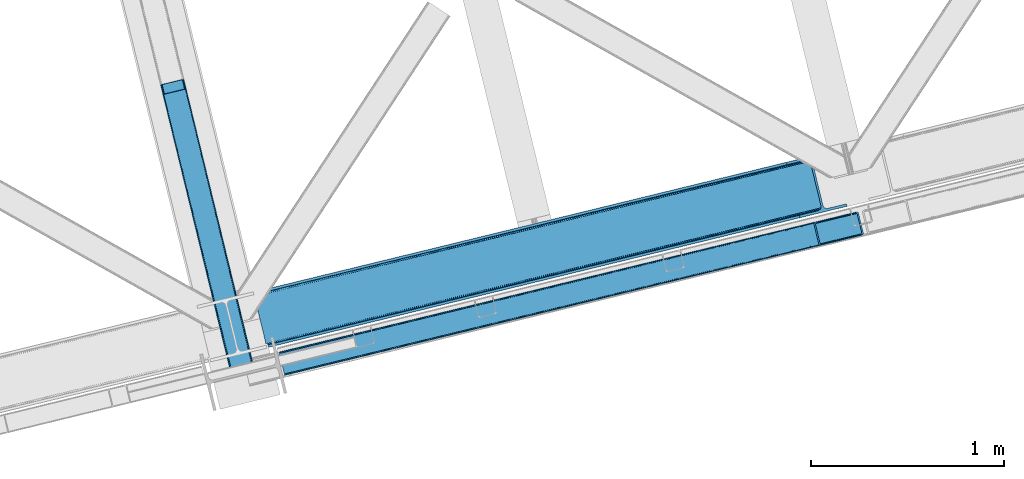
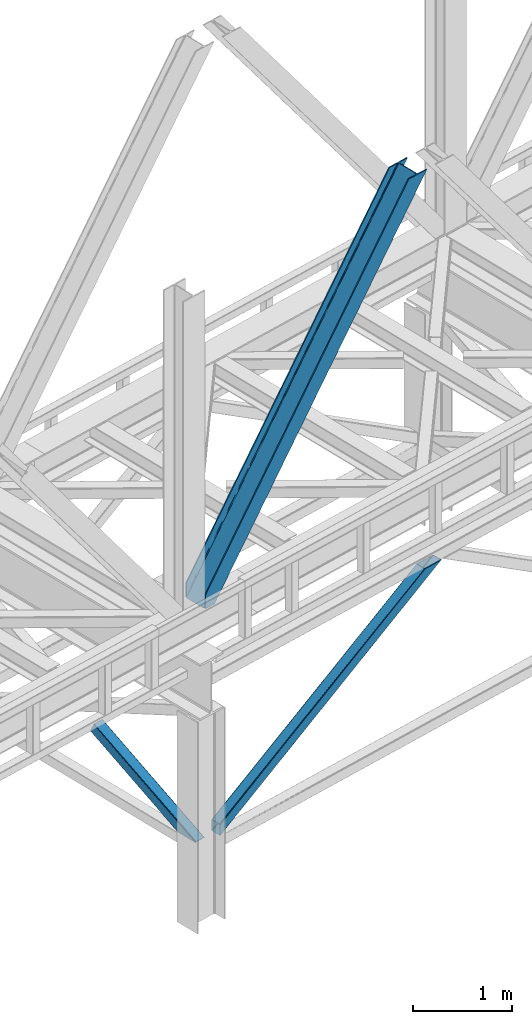
# One storey, part 42 of 93: 3 members.
"""IFC4 building model written with IfcOpenShell, lengths in millimetres."""

from ifc_helpers import new_model, entity, si_unit, converted_unit, derived_unit, direction, frame, origin, place, context, subcontext, project, spatial, triangles, polygons, type_object, element, save


model = new_model("IFC4")

# Units and contexts
model_context = context("Model", 3, precision=0.01, world=origin(), true_north=direction((6.12303176911189e-17, 1.0)))
plan_context = context("Plan", 3, precision=0.01, world=origin(), true_north=direction((6.12303176911189e-17, 1.0)))
body_context = subcontext(model_context, "Body", "Model", "MODEL_VIEW")
ifc_project = project(units=[si_unit("LENGTHUNIT", "METRE", prefix="MILLI"), si_unit("AREAUNIT", "SQUARE_METRE"), si_unit("VOLUMEUNIT", "CUBIC_METRE"), converted_unit("PLANEANGLEUNIT", "DEGREE", entity("IfcRatioMeasure", 0.0174532925199433), si_unit("PLANEANGLEUNIT", "RADIAN"), dimensions=[0, 0, 0, 0, 0, 0, 0]), si_unit("MASSUNIT", "GRAM", prefix="KILO"), derived_unit("MASSDENSITYUNIT", [(si_unit("MASSUNIT", "GRAM", prefix="KILO"), 1), (si_unit("LENGTHUNIT", "METRE"), -3)]), derived_unit("MOMENTOFINERTIAUNIT", [(si_unit("LENGTHUNIT", "METRE"), 4)]), si_unit("TIMEUNIT", "SECOND"), si_unit("FREQUENCYUNIT", "HERTZ"), si_unit("THERMODYNAMICTEMPERATUREUNIT", "DEGREE_CELSIUS"), derived_unit("THERMALTRANSMITTANCEUNIT", [(si_unit("MASSUNIT", "GRAM", prefix="KILO"), 1), (si_unit("THERMODYNAMICTEMPERATUREUNIT", "KELVIN"), -1), (si_unit("TIMEUNIT", "SECOND"), -3)]), derived_unit("VOLUMETRICFLOWRATEUNIT", [(si_unit("LENGTHUNIT", "METRE"), 3), (si_unit("TIMEUNIT", "SECOND"), -1)]), derived_unit("MASSFLOWRATEUNIT", [(si_unit("MASSUNIT", "GRAM", prefix="KILO"), 1), (si_unit("TIMEUNIT", "SECOND"), -1)]), derived_unit("ROTATIONALFREQUENCYUNIT", [(si_unit("TIMEUNIT", "SECOND"), -1)]), si_unit("ELECTRICCURRENTUNIT", "AMPERE"), si_unit("ELECTRICVOLTAGEUNIT", "VOLT"), si_unit("POWERUNIT", "WATT"), si_unit("FORCEUNIT", "NEWTON", prefix="KILO"), si_unit("ILLUMINANCEUNIT", "LUX"), si_unit("LUMINOUSFLUXUNIT", "LUMEN"), si_unit("LUMINOUSINTENSITYUNIT", "CANDELA"), derived_unit("USERDEFINED", [(si_unit("MASSUNIT", "GRAM", prefix="KILO"), -1), (si_unit("LENGTHUNIT", "METRE"), -2), (si_unit("TIMEUNIT", "SECOND"), 3), (si_unit("LUMINOUSFLUXUNIT", "LUMEN"), 1)]), derived_unit("LINEARVELOCITYUNIT", [(si_unit("LENGTHUNIT", "METRE"), 1), (si_unit("TIMEUNIT", "SECOND"), -1)]), si_unit("PRESSUREUNIT", "PASCAL"), derived_unit("USERDEFINED", [(si_unit("LENGTHUNIT", "METRE"), -2), (si_unit("MASSUNIT", "GRAM", prefix="KILO"), 1), (si_unit("TIMEUNIT", "SECOND"), -2)]), derived_unit("LINEARFORCEUNIT", [(si_unit("MASSUNIT", "GRAM", prefix="KILO"), 1), (si_unit("LENGTHUNIT", "METRE"), 1), (si_unit("TIMEUNIT", "SECOND"), -2), (si_unit("LENGTHUNIT", "METRE"), -1)]), derived_unit("PLANARFORCEUNIT", [(si_unit("MASSUNIT", "GRAM", prefix="KILO"), 1), (si_unit("LENGTHUNIT", "METRE"), 1), (si_unit("TIMEUNIT", "SECOND"), -2), (si_unit("LENGTHUNIT", "METRE"), -2)])], contexts=[model_context, plan_context])

# Site, building, storey
site_placement = place(None, origin())
site = spatial("IfcSite", under=ifc_project, at=site_placement, CompositionType="ELEMENT")
building_placement = place(site_placement, origin())
building = spatial("IfcBuilding", under=site, at=building_placement, CompositionType="ELEMENT")
storey_placement = place(building_placement, frame((0.0, 0.0, 15900.0)))
storey = spatial("IfcBuildingStorey", under=building, at=storey_placement, CompositionType="ELEMENT", Elevation=15900.0)

# Members
member_type_1 = type_object("IfcMemberType", PredefinedType="BRACE")
member_1_placement = place(storey_placement, frame((-41961.0666503906, 7062.34799194336, 965.735650634766)))
element("IfcMember", 1, at=member_1_placement, inside=storey, type_object=member_type_1, ObjectType="Steel Vertical Brace", PredefinedType="BRACE", context=body_context, shape_type="Tessellation", body=[
    triangles([(2998.54487915039, 840.490557861329, 1902.27225952148), (3024.23633422852, 734.561558532715, 1902.27225952148), (42.5415893554673, 11.3696548461912, 4.45903015136719), (16.6222412109346, 117.244006347656, 4.31717834472511), (0.176733398438955, 120.724607849122, 0.782510375975107), (0.0, 121.44375, 4.34159545898365), (2981.88078002929, 844.680418395997, 1902.27225952148), (2987.68042602539, 845.46060333252, 1902.27225952148), (2992.88243408203, 844.93796081543, 1902.27225952148), (7.26932373047021, 120.796115112305, 1.96615905761428), (2996.69848022461, 843.192718505859, 1902.27225952148), (13.8131103515625, 119.713041687012, 3.70442504882521), (0.213940429683134, 120.566477966308, 0.0), (3016.85538940429, 725.165620422364, 1902.27225952148), (29.4307617187515, 0.712165832519531, 0.868551635740005), (35.8768798828096, 3.93231811523492, 2.12312622070021), (29.3935546875, 0.86041259765625, 0.127899169921875), (3011.34642333984, 723.202949523926, 1902.27225952148), (29.6028442382813, 0.0, 4.43112487792678), (3021.24349365234, 728.014283752442, 1902.27225952148), (3023.83403320312, 731.313500976563, 1902.27225952148), (41.1835327148438, 7.89079742431659, 3.85441589355469), (0.0, 121.44375, 132.509353637695), (2780.51400146484, 795.840376281739, 1902.27225952148), (0.27440185546584, 120.305447387695, 135.835894775388), (2775.00270996094, 793.876542663575, 1902.27225952148), (0.55345458984084, 119.167726135254, 139.162435913084), (2770.61693115234, 791.02846069336, 1902.27225952148), (1.22318115234521, 116.419638061524, 140.541421508788), (2768.02639160156, 787.729243469239, 1902.27225952148), (1.89290771484229, 113.671549987793, 141.921569824219), (2767.62176513672, 784.481185913086, 1902.27225952148), (2793.31322021484, 678.552767944337, 1902.27225952148), (27.709936523439, 7.77220001220758, 141.999472045896), (28.379663085936, 5.02411193847638, 140.622811889647), (2795.15961914062, 675.850025939942, 1902.27225952148), (29.0493896484331, 2.27660522460974, 139.247314453125), (2798.97333984375, 674.104783630371, 1902.27225952148), (29.3237915039063, 1.13830261230487, 135.92309875488), (2804.17767333984, 673.582722473145, 1902.27225952148), (29.6028442382813, 0.0, 132.597720336911), (2809.97731933594, 674.362326049805, 1902.27225952148), (3.90208740234084, 110.042120361329, 0.32207336425563), (27.914575195311, 11.9382247924805, 0.453460693359375), (27.3053100585894, 9.42209930419904, 0.118597412107192), (2.32078857421584, 111.926307678223, 0.00930175781104481), (3015.90428466797, 736.656198120118, 1902.27225952148), (2992.09876098633, 834.810671997071, 1902.27225952148), (1.62315673827834, 114.773808288574, 3.08236999511428), (2986.43864135742, 839.258656311035, 1902.27225952148), (2981.23430786133, 839.780717468262, 1902.27225952148), (2.17196044921729, 112.539060974122, 0.67088928222438), (2990.25236206054, 837.513414001465, 1902.27225952148), (1.09295654296875, 116.966116333008, 5.44850463866896), (2975.43466186523, 839.001113891602, 1902.27225952148), (0.94877929687209, 117.557940673828, 9.04828491210719), (28.379663085936, 5.02411193847638, 5.80429687499782), (28.6540649414019, 3.88580932617242, 9.13083801269386), (3003.01204833984, 725.297589111328, 1902.27225952148), (28.100610351561, 6.16241455078125, 2.47775573730178), (3008.5256652832, 727.261422729493, 1902.27225952148), (27.4680908203081, 8.76167449951208, 0.596475219725107), (3012.90911865234, 730.108923339844, 1902.27225952148), (3015.50198364258, 733.408721923828, 1902.27225952148), (0.94877929687209, 117.557940673828, 127.808477783201), (2788.84837646484, 793.745155334473, 1902.27225952148), (2.17196044921729, 112.533247375489, 135.841708374021), (2776.35611572266, 785.634603881836, 1902.27225952148), (2775.95148925781, 782.385964965821, 1902.27225952148), (1.50223388672021, 115.281335449219, 134.461560058593), (2778.95130615234, 788.933821105958, 1902.27225952148), (1.22318115234521, 116.419638061524, 131.135018920897), (2783.33708496093, 791.781903076172, 1902.27225952148), (2.84168701171438, 109.785159301758, 137.220693969724), (2805.42410888672, 679.784669494629, 1902.27225952148), (2801.60573730469, 681.529911804199, 1902.27225952148), (2816.4234375, 680.041630554199, 1902.27225952148), (2810.62844238281, 679.26202697754, 1902.27225952148), (2799.75933837891, 684.231491088867, 1902.27225952148), (28.379663085936, 5.02411193847638, 131.216409301756), (28.100610351561, 6.16241455078125, 134.541787719725), (27.430883789064, 8.91050262451154, 135.917285156247), (26.7611572265596, 11.6585906982427, 137.292782592773), (28.6540649414019, 3.88580932617242, 127.891030883788)], [[1, 2, 3], [3, 4, 1], [5, 6, 7], [8, 9, 10], [10, 5, 8], [11, 1, 4], [4, 12, 11], [9, 11, 12], [12, 10, 9], [10, 13, 5], [7, 8, 5], [14, 15, 16], [15, 17, 16], [15, 14, 18], [18, 19, 15], [16, 20, 14], [21, 20, 22], [16, 22, 20], [2, 21, 3], [22, 3, 21], [6, 23, 24], [24, 7, 6], [23, 25, 26], [25, 27, 28], [27, 29, 30], [29, 31, 32], [32, 30, 29], [30, 28, 27], [28, 26, 25], [26, 24, 23], [33, 32, 34], [31, 34, 32], [35, 36, 33], [37, 38, 36], [39, 40, 38], [41, 42, 40], [40, 39, 41], [38, 37, 39], [36, 35, 37], [33, 34, 35], [41, 19, 42], [18, 42, 19], [43, 10, 12], [44, 3, 22], [44, 22, 16], [3, 44, 4], [12, 4, 43], [43, 4, 44], [16, 45, 44], [16, 17, 45], [10, 46, 13], [46, 10, 43], [47, 48, 44], [43, 44, 48], [49, 50, 51], [52, 53, 50], [53, 46, 43], [53, 52, 46], [43, 48, 53], [50, 49, 52], [51, 54, 49], [51, 55, 54], [56, 54, 55], [57, 58, 59], [60, 57, 61], [62, 60, 63], [64, 47, 44], [44, 45, 64], [45, 62, 64], [63, 64, 62], [61, 63, 60], [59, 61, 57], [65, 56, 66], [55, 66, 56], [67, 68, 69], [70, 71, 68], [72, 73, 71], [65, 66, 73], [73, 72, 65], [71, 70, 72], [68, 67, 70], [69, 74, 67], [53, 9, 8], [48, 2, 1], [11, 53, 1], [53, 11, 9], [53, 48, 1], [50, 53, 8], [55, 7, 24], [7, 50, 8], [51, 7, 55], [51, 50, 7], [20, 64, 14], [47, 2, 48], [2, 64, 21], [64, 2, 47], [20, 21, 64], [18, 59, 42], [14, 64, 63], [63, 61, 18], [61, 59, 18], [18, 14, 63], [71, 26, 68], [24, 66, 55], [24, 73, 66], [71, 24, 26], [71, 73, 24], [69, 32, 33], [68, 26, 28], [30, 68, 28], [68, 30, 32], [69, 68, 32], [40, 75, 76], [42, 59, 77], [77, 78, 42], [78, 75, 42], [40, 42, 75], [38, 40, 76], [33, 79, 69], [76, 33, 36], [33, 76, 79], [36, 38, 76], [41, 39, 80], [81, 35, 82], [37, 81, 39], [81, 37, 35], [80, 39, 81], [83, 31, 74], [82, 35, 34], [34, 83, 82], [34, 31, 83], [80, 84, 41], [19, 60, 17], [19, 41, 84], [84, 58, 19], [19, 58, 57], [60, 19, 57], [60, 62, 17], [23, 65, 72], [70, 25, 72], [31, 29, 67], [31, 67, 74], [67, 29, 70], [25, 23, 72], [70, 29, 27], [70, 27, 25], [23, 56, 65], [49, 13, 46], [49, 54, 5], [5, 13, 49], [54, 56, 6], [23, 6, 56], [54, 6, 5], [69, 79, 83], [83, 74, 69], [84, 80, 78], [80, 81, 75], [81, 82, 76], [82, 83, 79], [79, 76, 82], [76, 75, 81], [75, 78, 80], [78, 77, 84], [58, 84, 77], [77, 59, 58]]),
])
member_type_2 = type_object("IfcMemberType", PredefinedType="BRACE")
member_2_placement = place(storey_placement, frame((-42089.4448608398, 7208.30478057861, 3694.99929199219)))
element("IfcMember", 2, at=member_2_placement, inside=storey, type_object=member_type_2, ObjectType="Steel Vertical Brace", PredefinedType="BRACE", context=body_context, shape_type="Tessellation", body=[
    triangles([(58.5266601562471, 27.8796936035151, 0.0), (60.4474731445298, 20.0011047363278, 0.0), (59.0940673828154, 20.928955078125, 0.827856445310317), (58.9684936523408, 19.7534454345705, 1.13248901367115), (72.2095458984404, 11.6585906982418, 0.0), (71.3956420898467, 13.9003143310547, 30.563250732419), (70.2236206054658, 15.4356857299799, 25.1542785644524), (72.2095458984404, 11.6585906982418, 171.175598144531), (71.9258422851563, 12.6195785522459, 42.2602111816377), (71.9258422851563, 12.6195785522459, 171.115136718749), (70.3910522460938, 15.5600967407227, 0.0), (68.8144042968779, 17.2873168945307, 18.6337463378877), (67.2145019531235, 18.4651519775389, 14.6921264648408), (63.168237304686, 19.929597473144, 7.29955444335792), (63.168237304686, 19.929597473144, 0.0), (67.2145019531235, 18.4651519775389, 0.0), (2821.27895507812, 682.803089904785, 3911.00081176758), (2916.00805664063, 705.89354095459, 3911.00081176758), (2933.63488769531, 721.627464294434, 3911.00081176758), (2930.26300048828, 714.795323181153, 3911.00081176758), (2933.67209472656, 728.727030944824, 3911.00081176758), (2924.07268066406, 709.270079040527, 3911.00081176758), (2824.35783691406, 670.173046875, 3911.00081176758), (75.0512329101548, 0.0, 171.175598144531), (75.0512329101548, 0.0, 0.0), (192.881249999999, 28.7220840454102, 0.0), (3068.02668457032, 729.569421386719, 3911.00081176758), (3064.94780273437, 742.199464416504, 3911.00081176758), (189.802368164063, 41.3521270751953, 0.0), (2970.22335205078, 719.109594726562, 3911.00081176758), (95.0779174804702, 18.2622573852541, 0.0), (2961.50295410156, 718.394522094726, 3911.00081176758), (86.3575195312515, 17.5477661132809, 0.0), (2953.46623535156, 720.451373291015, 3911.00081176758), (78.32080078125, 19.6040359497065, 0.0), (2947.32707519531, 724.966213989258, 3911.00081176758), (72.181640625, 24.118876647949, 0.0), (2944.02960205078, 731.251295471191, 3911.00081176758), (68.8841674804717, 30.403958129883, 0.0), (2888.84692382813, 957.622943115234, 3911.00081176758), (13.7014892578154, 256.775605773926, 0.0), (2888.88413085938, 964.722509765625, 3911.00081176758), (13.7386962890596, 263.875172424317, 0.0), (2892.25601806641, 971.554650878907, 3911.00081176758), (17.1105834960908, 270.707313537598, 0.0), (2898.44633789062, 977.079895019531, 3911.00081176758), (23.3009033203125, 276.232557678222, 0.0), (2906.51561279297, 980.457014465332, 3911.00081176758), (31.3701782226563, 279.609677124024, 0.0), (3001.24006347657, 1003.54746551514, 3911.00081176758), (126.094628906249, 302.700128173828, 0.0), (2998.16118164062, 1016.17750854492, 3911.00081176758), (123.015747070313, 315.330171203614, 0.0), (2878.48941650391, 955.098678588867, 3911.00081176758), (3.34398193359084, 254.251341247558, 0.0), (2869.05278320312, 965.898600769043, 3911.00081176758), (2861.01606445313, 967.955451965332, 3911.00081176758), (2754.49233398437, 956.78055267334, 3911.00081176758), (2852.30031738281, 967.241542053222, 3911.00081176758), (2757.57121582031, 944.150509643555, 3911.00081176758), (2875.19194335937, 961.383760070801, 3911.00081176758), (5.18572998046875, 286.608087158203, 171.175598144531), (5.18572998046875, 286.608087158203, 0.0), (8.02741699219041, 274.949496459961, 171.175598144531), (8.22275390625146, 273.966998291015, 171.115136718749), (8.22275390625146, 273.966998291015, 42.2602111816377), (8.02741699219041, 274.949496459961, 0.0), (3.80906982421584, 263.445547485351, 0.0), (6.72517089844041, 266.608145141601, 0.0), (8.20880126953125, 270.64917755127, 0.0), (1.42316894531541, 262.130511474609, 0.0), (3.80906982421584, 263.445547485351, 7.29955444335792), (8.33902587890771, 272.585105895996, 30.563250732419), (8.20880126953125, 270.64917755127, 24.1799194335908), (7.30653076172166, 268.181886291504, 18.3872497558586), (6.72517089844041, 266.608145141601, 14.6921264648408), (0.0, 261.670074462891, 1.13248901367115), (0.651123046875, 260.685250854493, 0.827856445310317)], [[1, 2, 3], [4, 3, 2], [5, 6, 7], [5, 8, 9], [10, 9, 8], [9, 6, 5], [11, 12, 13], [11, 7, 12], [14, 4, 2], [2, 15, 14], [16, 13, 14], [14, 15, 16], [13, 16, 11], [7, 11, 5], [17, 18, 10], [9, 10, 18], [19, 3, 14], [14, 20, 19], [14, 13, 20], [13, 12, 20], [3, 4, 14], [19, 21, 1], [1, 3, 19], [6, 20, 7], [6, 22, 20], [12, 7, 20], [18, 22, 9], [6, 9, 22], [8, 17, 10], [23, 8, 24], [8, 23, 17], [25, 24, 5], [8, 5, 24], [23, 26, 27], [26, 23, 24], [25, 26, 24], [28, 27, 26], [26, 29, 28], [30, 28, 29], [29, 31, 30], [32, 30, 31], [31, 33, 32], [34, 32, 33], [33, 35, 34], [36, 34, 35], [35, 37, 36], [38, 36, 37], [37, 39, 38], [40, 38, 39], [39, 41, 40], [42, 40, 43], [41, 43, 40], [44, 42, 45], [43, 45, 42], [46, 44, 47], [45, 47, 44], [48, 46, 49], [47, 49, 46], [50, 48, 51], [49, 51, 48], [52, 50, 51], [51, 53, 52], [21, 54, 55], [55, 1, 21], [54, 21, 40], [20, 22, 32], [18, 23, 27], [17, 23, 18], [22, 18, 30], [21, 19, 36], [19, 20, 34], [56, 46, 57], [58, 59, 52], [59, 57, 48], [58, 60, 59], [56, 61, 44], [61, 54, 42], [40, 21, 38], [30, 32, 22], [36, 19, 34], [32, 34, 20], [36, 38, 21], [27, 30, 18], [27, 28, 30], [48, 57, 46], [44, 61, 42], [40, 42, 54], [44, 46, 56], [48, 52, 59], [52, 48, 50], [58, 53, 62], [58, 52, 53], [53, 63, 62], [64, 58, 62], [60, 64, 65], [64, 60, 58], [59, 60, 65], [65, 66, 59], [67, 64, 62], [62, 63, 67], [11, 35, 5], [68, 41, 55], [69, 70, 43], [69, 43, 68], [55, 71, 68], [67, 63, 47], [67, 45, 70], [55, 39, 1], [37, 16, 15], [2, 1, 15], [15, 1, 39], [11, 16, 37], [25, 5, 33], [39, 55, 41], [49, 47, 63], [43, 70, 45], [47, 45, 67], [43, 41, 68], [53, 49, 63], [53, 51, 49], [31, 25, 33], [35, 11, 37], [39, 37, 15], [35, 33, 5], [31, 26, 25], [26, 31, 29], [72, 68, 71], [67, 73, 66], [67, 70, 74], [74, 73, 67], [64, 67, 66], [66, 65, 64], [75, 70, 76], [75, 74, 70], [69, 76, 70], [76, 69, 72], [68, 72, 69], [71, 77, 72], [78, 61, 72], [61, 56, 75], [75, 76, 61], [76, 72, 61], [56, 57, 73], [73, 74, 56], [57, 59, 66], [66, 73, 57], [74, 75, 56], [72, 77, 78], [54, 61, 55], [78, 55, 61], [71, 55, 78], [78, 77, 71]]),
])
member_type_3 = type_object("IfcMemberType", PredefinedType="BRACE")
member_3_placement = place(storey_placement, frame((-42573.7490995148, 7071.32885087162, 970.499999998947)))
element("IfcMember", 3, at=member_3_placement, inside=storey, type_object=member_type_3, ObjectType="Steel Vertical Brace", PredefinedType="BRACE", context=body_context, shape_type="Tessellation", body=[
    polygons([(310.156875969811, 236.659699185643, 1.04388391264365e-09), (309.042346364983, 243.80328395698, 1.04171817838505e-09), (4.57230123623604, 1492.85694714149, 603.530503671959), (4.28876445601391, 1491.44877039324, 606.301796687595), (309.280773738958, 250.147759710236, 1.04604964690225e-09), (5.99595206163992, 1494.33917875157, 601.181114896126), (310.835859685345, 254.727237524783, 1.04604964690225e-09), (8.34297899944397, 1495.6698088973, 599.611303503947), (313.470856465746, 256.844533416439, 1.04604964690225e-09), (11.2560684742403, 1496.64626120118, 599.060059049498), (366.444630080972, 5.7456024138507, 1.00706643024751e-09), (14.4533090982387, 1449.74988433501, 697.72873436856), (411.597614338037, 280.763968808463, 1.04171817838505e-09), (109.38282634654, 1520.56569659321, 599.060059049498), (425.485457020332, 274.46076918091, 1.03522097560926e-09), (485.172065028787, 29.6032616237778, 9.24768528420827e-10), (481.0136271769, 28.5895984014798, 9.24768528420827e-10), (480.116220883526, 33.45425529372, 9.72414682109957e-10), (423.828466772364, 264.368352065512, 1.03305524135067e-09), (421.530657217859, 271.22349983026, 1.03522097560926e-09), (418.399388388624, 276.746576483304, 1.04171817838505e-09), (414.911367578928, 280.096743671035, 1.04171817838505e-09), (367.886495613074, 1.01366322182258, 9.29099996938021e-10), (363.72805776111, 1.08286712929839e-12, 5.76085312786745e-10), (304.041449752647, 244.857507557118, 1.03522097560926e-09), (302.926920147819, 252.001092328464, 1.03738670986786e-09), (303.165347521759, 258.345568081721, 1.03738670986786e-09), (304.720433468172, 262.925045896267, 1.04604964690225e-09), (307.355430248582, 265.042341787917, 1.04388391264365e-09), (413.254604585996, 290.856385923864, 1.04604964690225e-09), (416.568357826887, 290.18916078644, 1.05038111541944e-09), (420.056378636591, 286.838993598712, 1.04171817838505e-09), (423.18764746581, 281.315916945664, 1.04171817838505e-09), (112.418486893019, 1521.03931504355, 599.611303503942), (115.114566711323, 1520.93799552464, 601.181114896124), (117.060612089113, 1520.27716301478, 603.530503671959), (117.960355258576, 1519.15742327311, 606.301796687595), (128.124899900792, 1477.45853721488, 697.72873436856), (127.84136312057, 1476.05036046663, 700.500027384193), (126.417712295192, 1474.56812885655, 702.849416160034), (124.07068535738, 1473.23749871082, 704.419227552215), (121.157595882575, 1472.26104640693, 704.970472006657), (23.0308380102839, 1448.34161101491, 704.970472006657), (19.9951774637964, 1447.86799256457, 704.419227552218), (17.2990976454918, 1447.96931208348, 702.849416160031), (15.3530522677024, 1448.63014459335, 700.500027384193), (112.866478355649, 1523.16444199718, 595.439190230451), (6.9673040182264, 1497.35039786123, 595.439190230451), (4.05421454341274, 1496.37394555734, 595.990434684895), (1.70718760560003, 1495.04331541162, 597.560246077074), (0.28353678022213, 1493.56108380154, 599.909634852911), (0.0, 1492.15290705329, 602.680927868548), (10.9696570891299, 1447.15113893104, 701.349603187608), (11.8694002586022, 1446.03139918938, 704.120896203244), (13.8154456363916, 1445.37056667951, 706.470284979081), (16.5115254546789, 1445.2692471606, 708.040096371263), (19.5471860011663, 1445.74286561094, 708.591340825705), (125.446360338597, 1471.55690974689, 708.591340825705), (128.359449813402, 1472.53336205077, 708.040096371265), (130.706476751215, 1473.8639921965, 706.470284979079), (132.130127576593, 1475.34622380658, 704.120896203244), (132.413664356815, 1476.75440055483, 701.349603187608), (121.444007267685, 1521.75616867708, 602.680927868548), (120.544264098221, 1522.87590841874, 599.909634852913), (118.598218720423, 1523.53674092861, 597.560246077077), (115.902138902136, 1523.63806044752, 595.990434684897), (375.386682458807, 2.84191311588595, 6.51916727653314), (372.638718264444, 2.17206777061952, 5.2249222388966), (369.890754070107, 1.50222242536609, 3.93067720124058), (368.373326648033, 1.13233343716275, 0.954754934343811), (480.407239662007, 28.4417850297799, 0.783330976602792), (478.425418155212, 27.9586950702373, 3.34344663920135), (476.487815341744, 27.4863838850221, 5.84644062407408), (473.513440331098, 26.7613485079091, 6.51916727653314), (485.172065028795, 29.6032616237615, 2.10033831597304), (484.033820990575, 29.325802597071, 5.22492223888794), (482.895576952364, 29.0483435703729, 8.34950616180717), (480.147612758018, 28.3784982251108, 9.64375119945237), (477.399648563664, 27.7086528798498, 10.9379962370932), (371.500474226233, 1.8946087439236, 10.9379962370954), (368.752510031887, 1.22476339866151, 9.6437511994502), (366.004545837558, 0.55491805340375, 8.34950616180934), (364.866301799321, 0.277459026701334, 5.2249222388901), (363.72805776111, 2.16573425859679e-12, 2.10033831597304)], [[[1, 2, 3, 4]], [[2, 5, 6, 3]], [[5, 7, 8, 6]], [[7, 9, 10, 8]], [[11, 1, 4, 12]], [[9, 13, 14, 10]], [[15, 16, 17, 18, 19, 20, 21, 22, 13, 9, 7, 5, 2, 1, 11, 23, 24, 25, 26, 27, 28, 29, 30, 31, 32, 33]], [[47, 48, 49, 50, 51, 52, 53, 54, 55, 56, 57, 58, 59, 60, 61, 62, 63, 64, 65, 66], [10, 14, 34, 35, 36, 37, 38, 39, 40, 41, 42, 43, 44, 45, 46, 12, 4, 3, 6, 8]], [[13, 22, 34, 14]], [[22, 21, 35, 34]], [[21, 20, 36, 35]], [[20, 19, 37, 36]], [[19, 18, 38, 37]], [[44, 67, 68]], [[45, 68, 69]], [[46, 69, 70]], [[46, 11, 12]], [[11, 70, 23]], [[11, 46, 70]], [[69, 46, 45]], [[68, 45, 44]], [[67, 44, 43]], [[71, 18, 17]], [[39, 72, 40]], [[40, 73, 41]], [[73, 74, 42, 41]], [[73, 40, 72]], [[72, 39, 71]], [[39, 18, 71]], [[18, 39, 38]], [[42, 74, 67, 43]], [[16, 75, 76, 77, 78, 79, 80, 81, 82, 83, 84, 24, 23, 70, 69, 68, 67, 74, 73, 72, 71, 17]], [[29, 28, 49, 48]], [[28, 27, 50, 49]], [[27, 26, 51, 50]], [[26, 25, 52, 51]], [[47, 30, 29, 48]], [[15, 33, 64, 63]], [[33, 32, 65, 64]], [[32, 31, 66, 65]], [[31, 30, 47, 66]], [[24, 84, 53, 52, 25]], [[75, 16, 15, 63, 62]], [[53, 83, 54]], [[54, 82, 55]], [[55, 81, 56]], [[56, 80, 57]], [[80, 56, 81]], [[81, 55, 82]], [[82, 54, 83]], [[83, 53, 84]], [[80, 79, 58, 57]], [[59, 79, 78]], [[60, 78, 77]], [[61, 77, 76]], [[62, 76, 75]], [[76, 62, 61]], [[77, 61, 60]], [[78, 60, 59]], [[79, 59, 58]]], closed=True),
])

save(model, "model.ifc")
